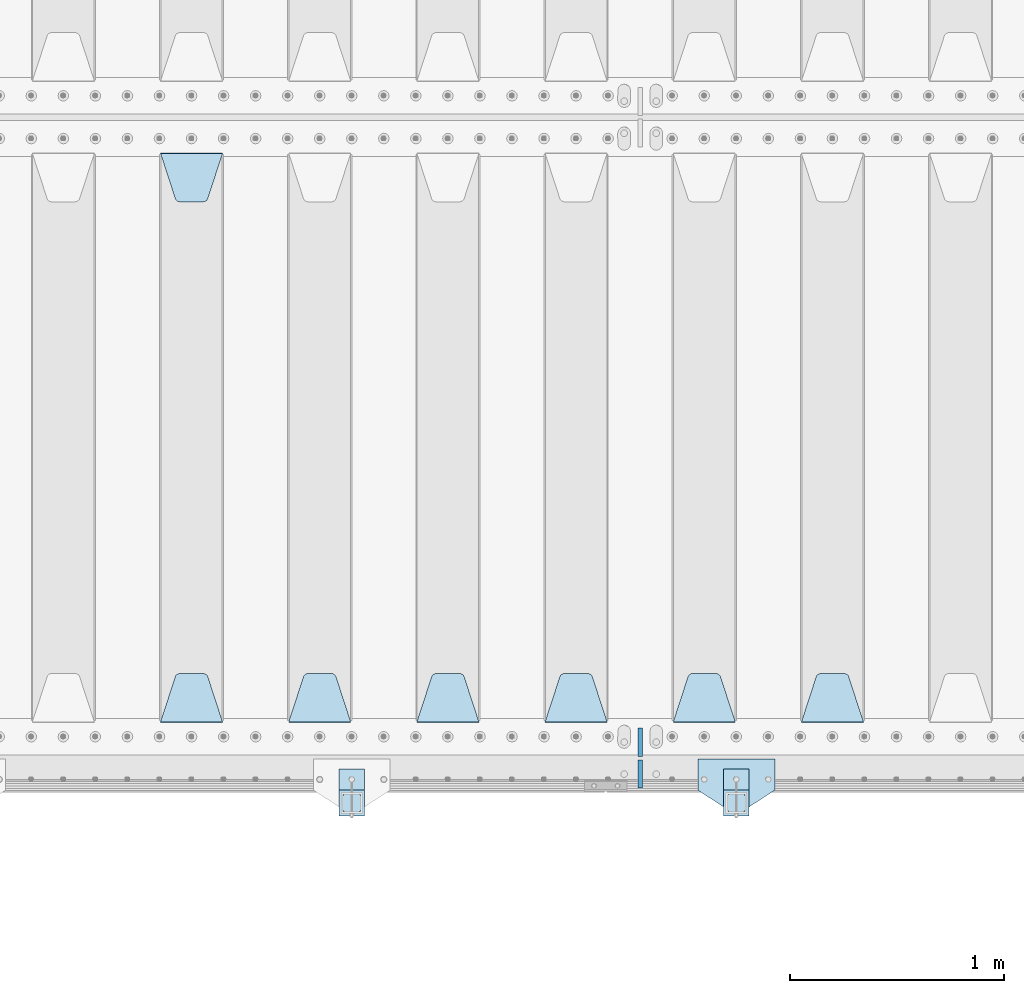
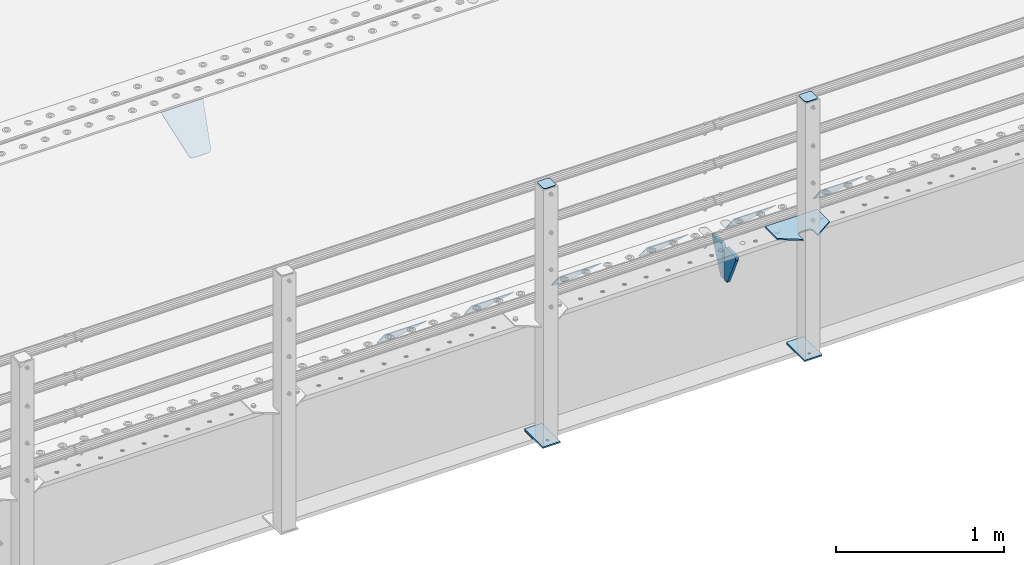
# One storey, part 168 of 208: 16 plates.
"""IFC2X3 building model written with IfcOpenShell, lengths in millimetres."""

from ifc_helpers import new_model, si_unit, frame, origin_with_axes, place, context, subcontext, project, spatial, faceted_brep, material, type_object, element, save


model = new_model("IFC2X3")

# Units and contexts
model_context = context("Model", 3, precision=1e-05, world=origin_with_axes())
body_context = subcontext(model_context, "Body", "Model", "MODEL_VIEW")
ifc_project = project(units=[si_unit("LENGTHUNIT", "METRE", prefix="MILLI"), si_unit("AREAUNIT", "SQUARE_METRE"), si_unit("VOLUMEUNIT", "CUBIC_METRE"), si_unit("MASSUNIT", "GRAM", prefix="KILO"), si_unit("TIMEUNIT", "SECOND"), si_unit("PLANEANGLEUNIT", "RADIAN"), si_unit("SOLIDANGLEUNIT", "STERADIAN"), si_unit("THERMODYNAMICTEMPERATUREUNIT", "DEGREE_CELSIUS"), si_unit("LUMINOUSINTENSITYUNIT", "LUMEN")], contexts=[model_context])

# Site, building, storey
site_placement = place(None, origin_with_axes())
site = spatial("IfcSite", under=ifc_project, at=site_placement, CompositionType="ELEMENT")
building_placement = place(site_placement, origin_with_axes())
building = spatial("IfcBuilding", under=site, at=building_placement, Name="Standard", CompositionType="ELEMENT")
storey_placement = place(building_placement, origin_with_axes())
storey = spatial("IfcBuildingStorey", under=building, at=storey_placement, Name="Undefined", CompositionType="ELEMENT", Elevation=0.0)

# Plates
ifc_material_1 = material(Name="STEEL/S355N")
plate_type_1 = type_object("IfcPlateType", PredefinedType="NOTDEFINED")
plate_1_placement = place(storey_placement, frame((-35905.0, 168.232233047023, -1.76776695296758), z_axis=(0.0, 0.707106781186547, -0.707106781186548), x_axis=(-1.0, 0.0, 0.0)))
element("IfcPlate", 1, at=plate_1_placement, inside=storey, type_object=plate_type_1, material=ifc_material_1, context=body_context, shape_type="Brep", body=[
    faceted_brep([(0.0, -2.5, 0.0), (69.345504679477, -2.5, 300.17173142483), (69.345504679477, 2.5, 300.17173142483), (0.0, 2.5, 0.0), (70.9274061199576, -2.5, 304.897442415399), (70.9274061199576, 2.5, 304.8974424154), (73.3818627772307, -2.5, 309.234538108527), (73.3818627772307, 2.5, 309.234538108527), (76.6187032999551, -2.5, 313.023683126103), (76.6187032999551, 2.5, 313.023683126103), (80.5190132704993, -2.5, 316.125672595371), (80.5190132704993, 2.5, 316.125672595371), (84.9395038596849, -2.5, 318.426546230476), (84.9395038596849, 2.50000000000091, 318.426546230476), (89.7177759439219, -2.5, 319.841774983275), (89.7177759439219, 2.50000000000091, 319.841774983275), (94.678286292652, -2.49999999999909, 320.319366455078), (94.678286292652, 2.5, 320.319366455078), (195.321713707348, -2.49999999999909, 320.319366455078), (195.321713707348, 2.5, 320.319366455078), (200.282224056078, -2.5, 319.841774983275), (200.282224056078, 2.5, 319.841774983274), (205.060496140315, -2.5, 318.426546230475), (205.060496140315, 2.5, 318.426546230475), (209.480986729501, -2.5, 316.125672595371), (209.480986729501, 2.50000000000091, 316.125672595371), (213.381296700045, -2.5, 313.023683126102), (213.381296700045, 2.5, 313.023683126102), (216.618137222769, -2.5, 309.234538108526), (216.618137222769, 2.5, 309.234538108527), (219.072593880042, -2.5, 304.897442415399), (219.072593880042, 2.5, 304.897442415399), (220.654495320523, -2.5, 300.17173142483), (220.654495320523, 2.5, 300.17173142483), (290.0, -2.5, 0.0), (290.0, 2.5, 0.0)], [[[0, 1, 2, 3]], [[1, 4, 5, 2]], [[4, 6, 7, 5]], [[6, 8, 9, 7]], [[8, 10, 11, 9]], [[10, 12, 13, 11]], [[12, 14, 15, 13]], [[14, 16, 17, 15]], [[16, 18, 19, 17]], [[18, 20, 21, 19]], [[20, 22, 23, 21]], [[22, 24, 25, 23]], [[24, 26, 27, 25]], [[26, 28, 29, 27]], [[28, 30, 31, 29]], [[30, 32, 33, 31]], [[32, 34, 35, 33]], [[34, 0, 3, 35]], [[5, 7, 9, 11, 13, 15, 17, 19, 21, 23, 25, 27, 29, 31, 33, 35, 3, 2]], [[34, 32, 30, 28, 26, 24, 22, 20, 18, 16, 14, 12, 10, 8, 6, 4, 1, 0]]]),
])
plate_2_placement = place(storey_placement, frame((-36505.0, 168.232233047023, -1.76776695296758), z_axis=(0.0, 0.707106781186547, -0.707106781186548), x_axis=(-1.0, 0.0, 0.0)))
element("IfcPlate", 2, at=plate_2_placement, inside=storey, type_object=plate_type_1, material=ifc_material_1, context=body_context, shape_type="Brep", body=[
    faceted_brep([(0.0, -2.5, 0.0), (69.345504679477, -2.5, 300.17173142483), (69.345504679477, 2.5, 300.17173142483), (0.0, 2.5, 0.0), (70.9274061199576, -2.5, 304.897442415399), (70.9274061199576, 2.5, 304.8974424154), (73.3818627772307, -2.5, 309.234538108527), (73.3818627772307, 2.5, 309.234538108527), (76.6187032999551, -2.5, 313.023683126103), (76.6187032999551, 2.5, 313.023683126103), (80.5190132704993, -2.5, 316.125672595371), (80.5190132704993, 2.5, 316.125672595371), (84.9395038596849, -2.5, 318.426546230476), (84.9395038596849, 2.50000000000091, 318.426546230476), (89.7177759439219, -2.5, 319.841774983275), (89.7177759439219, 2.50000000000091, 319.841774983275), (94.678286292652, -2.49999999999909, 320.319366455078), (94.678286292652, 2.5, 320.319366455078), (195.321713707348, -2.49999999999909, 320.319366455078), (195.321713707348, 2.5, 320.319366455078), (200.282224056078, -2.5, 319.841774983275), (200.282224056078, 2.5, 319.841774983274), (205.060496140315, -2.5, 318.426546230475), (205.060496140315, 2.5, 318.426546230475), (209.480986729501, -2.5, 316.125672595371), (209.480986729501, 2.50000000000091, 316.125672595371), (213.381296700045, -2.5, 313.023683126102), (213.381296700045, 2.5, 313.023683126102), (216.618137222769, -2.5, 309.234538108526), (216.618137222769, 2.5, 309.234538108527), (219.072593880042, -2.5, 304.897442415399), (219.072593880042, 2.5, 304.897442415399), (220.654495320523, -2.5, 300.17173142483), (220.654495320523, 2.5, 300.17173142483), (290.0, -2.5, 0.0), (290.0, 2.5, 0.0)], [[[0, 1, 2, 3]], [[1, 4, 5, 2]], [[4, 6, 7, 5]], [[6, 8, 9, 7]], [[8, 10, 11, 9]], [[10, 12, 13, 11]], [[12, 14, 15, 13]], [[14, 16, 17, 15]], [[16, 18, 19, 17]], [[18, 20, 21, 19]], [[20, 22, 23, 21]], [[22, 24, 25, 23]], [[24, 26, 27, 25]], [[26, 28, 29, 27]], [[28, 30, 31, 29]], [[30, 32, 33, 31]], [[32, 34, 35, 33]], [[34, 0, 3, 35]], [[5, 7, 9, 11, 13, 15, 17, 19, 21, 23, 25, 27, 29, 31, 33, 35, 3, 2]], [[34, 32, 30, 28, 26, 24, 22, 20, 18, 16, 14, 12, 10, 8, 6, 4, 1, 0]]]),
])
plate_3_placement = place(storey_placement, frame((-37105.0, 168.232233047023, -1.76776695296758), z_axis=(0.0, 0.707106781186547, -0.707106781186548), x_axis=(-1.0, 0.0, 0.0)))
element("IfcPlate", 3, at=plate_3_placement, inside=storey, type_object=plate_type_1, material=ifc_material_1, context=body_context, shape_type="Brep", body=[
    faceted_brep([(0.0, -2.5, 0.0), (69.345504679477, -2.5, 300.17173142483), (69.345504679477, 2.5, 300.17173142483), (0.0, 2.5, 0.0), (70.9274061199576, -2.5, 304.897442415399), (70.9274061199576, 2.5, 304.8974424154), (73.3818627772307, -2.5, 309.234538108527), (73.3818627772307, 2.5, 309.234538108527), (76.6187032999551, -2.5, 313.023683126103), (76.6187032999551, 2.5, 313.023683126103), (80.5190132704993, -2.5, 316.125672595371), (80.5190132704993, 2.5, 316.125672595371), (84.9395038596849, -2.5, 318.426546230476), (84.9395038596849, 2.50000000000091, 318.426546230476), (89.7177759439219, -2.5, 319.841774983275), (89.7177759439219, 2.50000000000091, 319.841774983275), (94.678286292652, -2.49999999999909, 320.319366455078), (94.678286292652, 2.5, 320.319366455078), (195.321713707348, -2.49999999999909, 320.319366455078), (195.321713707348, 2.5, 320.319366455078), (200.282224056078, -2.5, 319.841774983275), (200.282224056078, 2.5, 319.841774983274), (205.060496140315, -2.5, 318.426546230475), (205.060496140315, 2.5, 318.426546230475), (209.480986729501, -2.5, 316.125672595371), (209.480986729501, 2.50000000000091, 316.125672595371), (213.381296700045, -2.5, 313.023683126102), (213.381296700045, 2.5, 313.023683126102), (216.618137222769, -2.5, 309.234538108526), (216.618137222769, 2.5, 309.234538108527), (219.072593880042, -2.5, 304.897442415399), (219.072593880042, 2.5, 304.897442415399), (220.654495320523, -2.5, 300.17173142483), (220.654495320523, 2.5, 300.17173142483), (290.0, -2.5, 0.0), (290.0, 2.5, 0.0)], [[[0, 1, 2, 3]], [[1, 4, 5, 2]], [[4, 6, 7, 5]], [[6, 8, 9, 7]], [[8, 10, 11, 9]], [[10, 12, 13, 11]], [[12, 14, 15, 13]], [[14, 16, 17, 15]], [[16, 18, 19, 17]], [[18, 20, 21, 19]], [[20, 22, 23, 21]], [[22, 24, 25, 23]], [[24, 26, 27, 25]], [[26, 28, 29, 27]], [[28, 30, 31, 29]], [[30, 32, 33, 31]], [[32, 34, 35, 33]], [[34, 0, 3, 35]], [[5, 7, 9, 11, 13, 15, 17, 19, 21, 23, 25, 27, 29, 31, 33, 35, 3, 2]], [[34, 32, 30, 28, 26, 24, 22, 20, 18, 16, 14, 12, 10, 8, 6, 4, 1, 0]]]),
])
plate_4_placement = place(storey_placement, frame((-37705.0, 168.232233047023, -1.76776695296758), z_axis=(0.0, 0.707106781186547, -0.707106781186548), x_axis=(-1.0, 0.0, 0.0)))
element("IfcPlate", 4, at=plate_4_placement, inside=storey, type_object=plate_type_1, material=ifc_material_1, context=body_context, shape_type="Brep", body=[
    faceted_brep([(0.0, -2.5, 0.0), (69.345504679477, -2.5, 300.17173142483), (69.345504679477, 2.5, 300.17173142483), (0.0, 2.5, 0.0), (70.9274061199576, -2.5, 304.897442415399), (70.9274061199576, 2.5, 304.8974424154), (73.3818627772307, -2.5, 309.234538108527), (73.3818627772307, 2.5, 309.234538108527), (76.6187032999551, -2.5, 313.023683126103), (76.6187032999551, 2.5, 313.023683126103), (80.5190132704993, -2.5, 316.125672595371), (80.5190132704993, 2.5, 316.125672595371), (84.9395038596849, -2.5, 318.426546230476), (84.9395038596849, 2.50000000000091, 318.426546230476), (89.7177759439219, -2.5, 319.841774983275), (89.7177759439219, 2.50000000000091, 319.841774983275), (94.678286292652, -2.49999999999909, 320.319366455078), (94.678286292652, 2.5, 320.319366455078), (195.321713707348, -2.49999999999909, 320.319366455078), (195.321713707348, 2.5, 320.319366455078), (200.282224056078, -2.5, 319.841774983275), (200.282224056078, 2.5, 319.841774983274), (205.060496140315, -2.5, 318.426546230475), (205.060496140315, 2.5, 318.426546230475), (209.480986729501, -2.5, 316.125672595371), (209.480986729501, 2.50000000000091, 316.125672595371), (213.381296700045, -2.5, 313.023683126102), (213.381296700045, 2.5, 313.023683126102), (216.618137222769, -2.5, 309.234538108526), (216.618137222769, 2.5, 309.234538108527), (219.072593880042, -2.5, 304.897442415399), (219.072593880042, 2.5, 304.897442415399), (220.654495320523, -2.5, 300.17173142483), (220.654495320523, 2.5, 300.17173142483), (290.0, -2.5, 0.0), (290.0, 2.5, 0.0)], [[[0, 1, 2, 3]], [[1, 4, 5, 2]], [[4, 6, 7, 5]], [[6, 8, 9, 7]], [[8, 10, 11, 9]], [[10, 12, 13, 11]], [[12, 14, 15, 13]], [[14, 16, 17, 15]], [[16, 18, 19, 17]], [[18, 20, 21, 19]], [[20, 22, 23, 21]], [[22, 24, 25, 23]], [[24, 26, 27, 25]], [[26, 28, 29, 27]], [[28, 30, 31, 29]], [[30, 32, 33, 31]], [[32, 34, 35, 33]], [[34, 0, 3, 35]], [[5, 7, 9, 11, 13, 15, 17, 19, 21, 23, 25, 27, 29, 31, 33, 35, 3, 2]], [[34, 32, 30, 28, 26, 24, 22, 20, 18, 16, 14, 12, 10, 8, 6, 4, 1, 0]]]),
])
plate_5_placement = place(storey_placement, frame((-38305.0, 168.232233047023, -1.76776695296758), z_axis=(0.0, 0.707106781186547, -0.707106781186548), x_axis=(-1.0, 0.0, 0.0)))
element("IfcPlate", 5, at=plate_5_placement, inside=storey, type_object=plate_type_1, material=ifc_material_1, context=body_context, shape_type="Brep", body=[
    faceted_brep([(0.0, -2.5, 0.0), (69.345504679477, -2.5, 300.17173142483), (69.345504679477, 2.5, 300.17173142483), (0.0, 2.5, 0.0), (70.9274061199576, -2.5, 304.897442415399), (70.9274061199576, 2.5, 304.8974424154), (73.3818627772307, -2.5, 309.234538108527), (73.3818627772307, 2.5, 309.234538108527), (76.6187032999551, -2.5, 313.023683126103), (76.6187032999551, 2.5, 313.023683126103), (80.5190132704993, -2.5, 316.125672595371), (80.5190132704993, 2.5, 316.125672595371), (84.9395038596849, -2.5, 318.426546230476), (84.9395038596849, 2.50000000000091, 318.426546230476), (89.7177759439219, -2.5, 319.841774983275), (89.7177759439219, 2.50000000000091, 319.841774983275), (94.678286292652, -2.49999999999909, 320.319366455078), (94.678286292652, 2.5, 320.319366455078), (195.321713707348, -2.49999999999909, 320.319366455078), (195.321713707348, 2.5, 320.319366455078), (200.282224056078, -2.5, 319.841774983275), (200.282224056078, 2.5, 319.841774983274), (205.060496140315, -2.5, 318.426546230475), (205.060496140315, 2.5, 318.426546230475), (209.480986729501, -2.5, 316.125672595371), (209.480986729501, 2.50000000000091, 316.125672595371), (213.381296700045, -2.5, 313.023683126102), (213.381296700045, 2.5, 313.023683126102), (216.618137222769, -2.5, 309.234538108526), (216.618137222769, 2.5, 309.234538108527), (219.072593880042, -2.5, 304.897442415399), (219.072593880042, 2.5, 304.897442415399), (220.654495320523, -2.5, 300.17173142483), (220.654495320523, 2.5, 300.17173142483), (290.0, -2.5, 0.0), (290.0, 2.5, 0.0)], [[[0, 1, 2, 3]], [[1, 4, 5, 2]], [[4, 6, 7, 5]], [[6, 8, 9, 7]], [[8, 10, 11, 9]], [[10, 12, 13, 11]], [[12, 14, 15, 13]], [[14, 16, 17, 15]], [[16, 18, 19, 17]], [[18, 20, 21, 19]], [[20, 22, 23, 21]], [[22, 24, 25, 23]], [[24, 26, 27, 25]], [[26, 28, 29, 27]], [[28, 30, 31, 29]], [[30, 32, 33, 31]], [[32, 34, 35, 33]], [[34, 0, 3, 35]], [[5, 7, 9, 11, 13, 15, 17, 19, 21, 23, 25, 27, 29, 31, 33, 35, 3, 2]], [[34, 32, 30, 28, 26, 24, 22, 20, 18, 16, 14, 12, 10, 8, 6, 4, 1, 0]]]),
])
plate_6_placement = place(storey_placement, frame((-39195.0, 2831.76776695596, -1.76776695296758), z_axis=(0.0, -0.707106781186548, -0.707106781186547), x_axis=(1.0, 0.0, 0.0)))
element("IfcPlate", 6, at=plate_6_placement, inside=storey, type_object=plate_type_1, material=ifc_material_1, context=body_context, shape_type="Brep", body=[
    faceted_brep([(0.0, -2.5, 0.0), (69.345504679477, -2.5, 300.17173142483), (69.345504679477, 2.5, 300.17173142483), (0.0, 2.5, 0.0), (70.9274061199576, -2.5, 304.897442415399), (70.9274061199576, 2.5, 304.8974424154), (73.3818627772307, -2.5, 309.234538108527), (73.3818627772307, 2.5, 309.234538108527), (76.6187032999551, -2.5, 313.023683126103), (76.6187032999551, 2.5, 313.023683126103), (80.5190132704993, -2.5, 316.125672595371), (80.5190132704993, 2.5, 316.125672595371), (84.9395038596849, -2.5, 318.426546230476), (84.9395038596849, 2.50000000000091, 318.426546230476), (89.7177759439219, -2.5, 319.841774983275), (89.7177759439219, 2.50000000000091, 319.841774983275), (94.678286292652, -2.49999999999909, 320.319366455078), (94.678286292652, 2.5, 320.319366455078), (195.321713707348, -2.49999999999909, 320.319366455078), (195.321713707348, 2.5, 320.319366455078), (200.282224056078, -2.5, 319.841774983275), (200.282224056078, 2.5, 319.841774983274), (205.060496140315, -2.5, 318.426546230475), (205.060496140315, 2.5, 318.426546230475), (209.480986729501, -2.5, 316.125672595371), (209.480986729501, 2.50000000000091, 316.125672595371), (213.381296700045, -2.5, 313.023683126102), (213.381296700045, 2.5, 313.023683126102), (216.618137222769, -2.5, 309.234538108526), (216.618137222769, 2.5, 309.234538108527), (219.072593880042, -2.5, 304.897442415399), (219.072593880042, 2.5, 304.897442415399), (220.654495320523, -2.5, 300.17173142483), (220.654495320523, 2.5, 300.17173142483), (290.0, -2.5, 0.0), (290.0, 2.5, 0.0)], [[[0, 1, 2, 3]], [[1, 4, 5, 2]], [[4, 6, 7, 5]], [[6, 8, 9, 7]], [[8, 10, 11, 9]], [[10, 12, 13, 11]], [[12, 14, 15, 13]], [[14, 16, 17, 15]], [[16, 18, 19, 17]], [[18, 20, 21, 19]], [[20, 22, 23, 21]], [[22, 24, 25, 23]], [[24, 26, 27, 25]], [[26, 28, 29, 27]], [[28, 30, 31, 29]], [[30, 32, 33, 31]], [[32, 34, 35, 33]], [[34, 0, 3, 35]], [[5, 7, 9, 11, 13, 15, 17, 19, 21, 23, 25, 27, 29, 31, 33, 35, 3, 2]], [[34, 32, 30, 28, 26, 24, 22, 20, 18, 16, 14, 12, 10, 8, 6, 4, 1, 0]]]),
])
plate_7_placement = place(storey_placement, frame((-38905.0, 168.232233047023, -1.76776695296758), z_axis=(0.0, 0.707106781186547, -0.707106781186548), x_axis=(-1.0, 0.0, 0.0)))
element("IfcPlate", 7, at=plate_7_placement, inside=storey, type_object=plate_type_1, material=ifc_material_1, context=body_context, shape_type="Brep", body=[
    faceted_brep([(0.0, -2.5, 0.0), (69.345504679477, -2.5, 300.17173142483), (69.345504679477, 2.5, 300.17173142483), (0.0, 2.5, 0.0), (70.9274061199576, -2.5, 304.897442415399), (70.9274061199576, 2.5, 304.8974424154), (73.3818627772307, -2.5, 309.234538108527), (73.3818627772307, 2.5, 309.234538108527), (76.6187032999551, -2.5, 313.023683126103), (76.6187032999551, 2.5, 313.023683126103), (80.5190132704993, -2.5, 316.125672595371), (80.5190132704993, 2.5, 316.125672595371), (84.9395038596849, -2.5, 318.426546230476), (84.9395038596849, 2.50000000000091, 318.426546230476), (89.7177759439219, -2.5, 319.841774983275), (89.7177759439219, 2.50000000000091, 319.841774983275), (94.678286292652, -2.49999999999909, 320.319366455078), (94.678286292652, 2.5, 320.319366455078), (195.321713707348, -2.49999999999909, 320.319366455078), (195.321713707348, 2.5, 320.319366455078), (200.282224056078, -2.5, 319.841774983275), (200.282224056078, 2.5, 319.841774983274), (205.060496140315, -2.5, 318.426546230475), (205.060496140315, 2.5, 318.426546230475), (209.480986729501, -2.5, 316.125672595371), (209.480986729501, 2.50000000000091, 316.125672595371), (213.381296700045, -2.5, 313.023683126102), (213.381296700045, 2.5, 313.023683126102), (216.618137222769, -2.5, 309.234538108526), (216.618137222769, 2.5, 309.234538108527), (219.072593880042, -2.5, 304.897442415399), (219.072593880042, 2.5, 304.897442415399), (220.654495320523, -2.5, 300.17173142483), (220.654495320523, 2.5, 300.17173142483), (290.0, -2.5, 0.0), (290.0, 2.5, 0.0)], [[[0, 1, 2, 3]], [[1, 4, 5, 2]], [[4, 6, 7, 5]], [[6, 8, 9, 7]], [[8, 10, 11, 9]], [[10, 12, 13, 11]], [[12, 14, 15, 13]], [[14, 16, 17, 15]], [[16, 18, 19, 17]], [[18, 20, 21, 19]], [[20, 22, 23, 21]], [[22, 24, 25, 23]], [[24, 26, 27, 25]], [[26, 28, 29, 27]], [[28, 30, 31, 29]], [[30, 32, 33, 31]], [[32, 34, 35, 33]], [[34, 0, 3, 35]], [[5, 7, 9, 11, 13, 15, 17, 19, 21, 23, 25, 27, 29, 31, 33, 35, 3, 2]], [[34, 32, 30, 28, 26, 24, 22, 20, 18, 16, 14, 12, 10, 8, 6, 4, 1, 0]]]),
])
plate_type_2 = type_object("IfcPlateType", PredefinedType="NOTDEFINED")
for number, where, z_axis, x_axis in (
    (8, (-36950.0, 140.0, -30.0), (0.0, 0.0, -1.0), (0.0, -1.0, 0.0)),
    (9, (-36950.0, -140.0, -30.0), (0.0, 0.0, -1.0), (0.0, 1.0, 0.0)),
):
    element("IfcPlate", number, at=place(storey_placement, frame(where, z_axis=z_axis, x_axis=x_axis)), inside=storey, type_object=plate_type_2, material=ifc_material_1, context=body_context, shape_type="Brep", body=[
        faceted_brep([(0.0, -10.0, 0.0), (0.0, -10.0, 30.0), (0.0, 10.0, 30.0), (0.0, 10.0, 0.0), (102.0, -10.0, 250.0), (102.0, 10.0, 250.0), (132.0, -10.0, 250.0), (132.0, 10.0, 250.0), (132.0, -10.0, 30.0), (132.0, 10.0, 30.0), (131.544232590366, -10.0, 24.790554669992), (131.544232590366, 10.0, 24.790554669992), (130.190778623577, -10.0, 19.7393957002299), (130.190778623577, 10.0, 19.7393957002299), (127.980762113533, -10.0, 15.0), (127.980762113533, 10.0, 15.0), (124.981333293569, -10.0, 10.7163717094038), (124.981333293569, 10.0, 10.7163717094038), (121.283628290596, -10.0, 7.01866670643062), (121.283628290596, 10.0, 7.01866670643062), (117.0, -10.0, 4.01923788646684), (117.0, 10.0, 4.01923788646684), (112.26060429977, -10.0, 1.80922137642278), (112.26060429977, 10.0, 1.80922137642278), (107.209445330008, -10.0, 0.455767409633722), (107.209445330008, 10.0, 0.455767409633722), (102.0, -10.0, 0.0), (102.0, 10.0, 0.0)], [[[0, 1, 2, 3]], [[1, 4, 5, 2]], [[4, 6, 7, 5]], [[6, 8, 9, 7]], [[8, 10, 11, 9]], [[10, 12, 13, 11]], [[12, 14, 15, 13]], [[14, 16, 17, 15]], [[16, 18, 19, 17]], [[18, 20, 21, 19]], [[20, 22, 23, 21]], [[22, 24, 25, 23]], [[24, 26, 27, 25]], [[26, 0, 3, 27]], [[5, 7, 9, 11, 13, 15, 17, 19, 21, 23, 25, 27, 3, 2]], [[26, 24, 22, 20, 18, 16, 14, 12, 10, 8, 6, 4, 1, 0]]]),
    ])
ifc_material_2 = material(Name="STEEL/S355J2")
plate_type_3 = type_object("IfcPlateType", PredefinedType="NOTDEFINED")
plate_8_placement = place(storey_placement, frame((-36320.0, -4.99999999999636, 5.00000000004911), z_axis=(0.0, -1.0, 0.0), x_axis=(-1.0, 0.0, 0.0)))
element("IfcPlate", 10, at=plate_8_placement, inside=storey, type_object=plate_type_3, material=ifc_material_2, context=body_context, shape_type="Brep", body=[
    faceted_brep([(0.0, -5.0, 0.0), (2.31396552408114e-06, -5.0, 145.0), (2.31396552408114e-06, 5.0, 145.0), (0.0, 5.0, 0.0), (130.0, -5.0, 230.0), (130.0, 5.0, 230.0), (130.0, -5.0, 180.0), (130.0, 5.0, 180.0), (130.48036798992, -5.0, 175.122741949597), (130.48036798992, 5.0, 175.122741949597), (131.903011687216, -5.0, 170.432914190873), (131.903011687216, 5.0, 170.432914190873), (134.213259692435, -5.0, 166.11074417451), (134.213259692435, 5.0, 166.11074417451), (137.322330470335, -5.0, 162.322330470336), (137.322330470335, 5.0, 162.322330470336), (141.110744174512, -5.0, 159.213259692437), (141.110744174512, 5.0, 159.213259692437), (145.432914190871, -5.0, 156.903011687218), (145.432914190871, 5.0, 156.903011687218), (150.122741949595, -5.0, 155.48036798992), (150.122741949595, 5.0, 155.48036798992), (155.0, -5.0, 155.0), (155.0, 5.0, 155.0), (205.0, -5.0, 155.0), (205.0, 5.0, 155.0), (209.877258050405, -5.0, 155.48036798992), (209.877258050405, 5.0, 155.48036798992), (214.567085809129, -5.0, 156.903011687218), (214.567085809129, 5.0, 156.903011687218), (218.889255825488, -5.0, 159.213259692437), (218.889255825488, 5.0, 159.213259692437), (222.677669529665, -5.0, 162.322330470336), (222.677669529665, 5.0, 162.322330470336), (225.786740307565, -5.0, 166.11074417451), (225.786740307565, 5.0, 166.11074417451), (228.096988312784, -5.0, 170.432914190873), (228.096988312784, 5.0, 170.432914190873), (229.51963201008, -5.0, 175.122741949597), (229.51963201008, 5.0, 175.122741949597), (230.0, -5.0, 180.0), (230.0, 5.0, 180.0), (230.0, -5.0, 230.0), (230.0, 5.0, 230.0), (360.0, -5.0, 145.0), (360.0, 5.0, 145.0), (360.0, -5.0, -7.27595761418343e-12), (360.0, 5.0, -7.27595761418343e-12)], [[[0, 1, 2, 3]], [[1, 4, 5, 2]], [[4, 6, 7, 5]], [[6, 8, 9, 7]], [[8, 10, 11, 9]], [[10, 12, 13, 11]], [[12, 14, 15, 13]], [[14, 16, 17, 15]], [[16, 18, 19, 17]], [[18, 20, 21, 19]], [[20, 22, 23, 21]], [[22, 24, 25, 23]], [[24, 26, 27, 25]], [[26, 28, 29, 27]], [[28, 30, 31, 29]], [[30, 32, 33, 31]], [[32, 34, 35, 33]], [[34, 36, 37, 35]], [[36, 38, 39, 37]], [[38, 40, 41, 39]], [[40, 42, 43, 41]], [[42, 44, 45, 43]], [[44, 46, 47, 45]], [[46, 0, 3, 47]], [[5, 7, 9, 11, 13, 15, 17, 19, 21, 23, 25, 27, 29, 31, 33, 35, 37, 39, 41, 43, 45, 47, 3, 2]], [[46, 44, 42, 40, 38, 36, 34, 32, 30, 28, 26, 24, 22, 20, 18, 16, 14, 12, 10, 8, 6, 4, 1, 0]]]),
])
plate_type_4 = type_object("IfcPlateType", PredefinedType="NOTDEFINED")
for number, where, z_axis, x_axis in (
    (11, (-36440.0000000001, -50.0000000002074, -850.000000000002), (0.0, -1.0, 0.0), (-1.0, 0.0, 0.0)),
    (12, (-38240.0000000001, -50.0000000002074, -850.000000000002), (0.0, -1.0, 0.0), (-1.0, 0.0, 0.0)),
):
    element("IfcPlate", number, at=place(storey_placement, frame(where, z_axis=z_axis, x_axis=x_axis)), inside=storey, type_object=plate_type_4, material=ifc_material_2, context=body_context, shape_type="Brep", body=[
        faceted_brep([(53.6360389691836, -5.0, 176.36396103047), (53.6360389691836, 5.0, 176.36396103047), (59.9999999998618, 5.0, 178.999999999791), (59.9999999998618, -5.0, 178.999999999791), (66.3639610305399, 5.0, 176.36396103047), (66.3639610305399, -5.0, 176.36396103047), (68.9999999998618, 5.0, 169.999999999791), (68.9999999998618, -5.0, 169.999999999791), (66.3639610305399, 5.0, 163.636038969112), (66.3639610305399, -5.0, 163.636038969112), (59.9999999998618, 5.0, 160.999999999791), (59.9999999998618, -5.0, 160.999999999791), (53.6360389691836, 5.0, 163.636038969112), (53.6360389691836, -5.0, 163.636038969112), (50.9999999998618, 5.0, 169.999999999791), (50.9999999998618, -5.0, 169.999999999791), (120.0, -5.0, 0.0), (120.0, -5.0, 220.0), (0.0, -5.0, 220.0), (0.0, -5.0, 0.0), (0.0, 5.0, 0.0), (120.0, 5.0, 0.0), (120.0, 5.0, 220.0), (0.0, 5.0, 220.0)], [[[0, 1, 2, 3]], [[3, 2, 4, 5]], [[5, 4, 6, 7]], [[7, 6, 8, 9]], [[9, 8, 10, 11]], [[11, 10, 12, 13]], [[13, 12, 14, 15]], [[15, 14, 1, 0]], [[16, 17, 18, 19], [11, 13, 15, 0, 3, 5, 7, 9]], [[16, 19, 20, 21]], [[17, 16, 21, 22]], [[18, 17, 22, 23]], [[19, 18, 23, 20]], [[22, 21, 20, 23], [2, 1, 14, 12, 10, 8, 6, 4]]]),
    ])
plate_type_5 = type_object("IfcPlateType", PredefinedType="NOTDEFINED")
plate_9_placement = place(storey_placement, frame((-36544.0000000001, -166.000000000207, 1012.50000000001), z_axis=(0.0, -1.0, 0.0), x_axis=(1.0, 0.0, 0.0)))
element("IfcPlate", 13, at=plate_9_placement, inside=storey, type_object=plate_type_5, material=ifc_material_2, context=body_context, shape_type="Brep", body=[
    faceted_brep([(0.0, -2.5, 19.0), (0.0, -2.5, 69.0), (0.0, 2.5, 69.0), (0.0, 2.5, 19.0), (0.476369668544066, -2.5, 73.2278977451697), (0.476369668544066, 2.5, 73.2278977451697), (1.88159150985302, -2.5, 77.2437910432336), (1.88159150985302, 2.5, 77.2437910432336), (4.14520183310742, -2.5, 80.8463062353158), (4.14520183310742, 2.5, 80.8463062353158), (7.15369376468516, -2.5, 83.8547981668926), (7.15369376468516, 2.5, 83.8547981668926), (10.7562089567655, -2.5, 86.1184084901461), (10.7562089567655, 2.5, 86.1184084901461), (14.7721022548285, -2.5, 87.523630331455), (14.7721022548285, 2.5, 87.523630331455), (19.0, -2.5, 88.0), (19.0, 2.5, 88.0), (69.0, -2.5, 88.0), (69.0, 2.5, 88.0), (73.2278977451715, -2.5, 87.523630331455), (73.2278977451715, 2.5, 87.523630331455), (77.2437910432345, -2.5, 86.1184084901461), (77.2437910432345, 2.5, 86.1184084901461), (80.8463062353148, -2.5, 83.8547981668926), (80.8463062353148, 2.5, 83.8547981668926), (83.8547981668926, -2.5, 80.8463062353158), (83.8547981668926, 2.5, 80.8463062353158), (86.118408490147, -2.5, 77.2437910432336), (86.118408490147, 2.5, 77.2437910432336), (87.5236303314559, -2.5, 73.2278977451697), (87.5236303314559, 2.5, 73.2278977451697), (88.0, -2.5, 69.0), (88.0, 2.5, 69.0), (88.0, -2.5, 19.0), (88.0, 2.5, 19.0), (87.5236303314559, -2.5, 14.7721022548303), (87.5236303314559, 2.5, 14.7721022548303), (86.118408490147, -2.5, 10.7562089567664), (86.118408490147, 2.5, 10.7562089567664), (83.8547981668926, -2.5, 7.15369376468425), (83.8547981668926, 2.5, 7.15369376468425), (80.8463062353148, -2.5, 4.14520183310742), (80.8463062353148, 2.5, 4.14520183310742), (77.2437910432345, -2.5, 1.88159150985393), (77.2437910432345, 2.5, 1.88159150985393), (73.2278977451715, -2.5, 0.476369668544976), (73.2278977451715, 2.5, 0.476369668544976), (69.0, -2.5, 0.0), (69.0, 2.5, 0.0), (19.0, -2.5, 0.0), (19.0, 2.5, 0.0), (14.7721022548285, -2.5, 0.476369668544976), (14.7721022548285, 2.5, 0.476369668544976), (10.7562089567655, -2.5, 1.88159150985393), (10.7562089567655, 2.5, 1.88159150985393), (7.15369376468516, -2.5, 4.14520183310742), (7.15369376468516, 2.5, 4.14520183310742), (4.14520183310742, -2.5, 7.15369376468425), (4.14520183310742, 2.5, 7.15369376468425), (1.88159150985302, -2.5, 10.7562089567664), (1.88159150985302, 2.5, 10.7562089567664), (0.476369668544066, -2.5, 14.7721022548303), (0.476369668544066, 2.5, 14.7721022548303)], [[[0, 1, 2, 3]], [[1, 4, 5, 2]], [[4, 6, 7, 5]], [[6, 8, 9, 7]], [[8, 10, 11, 9]], [[10, 12, 13, 11]], [[12, 14, 15, 13]], [[14, 16, 17, 15]], [[16, 18, 19, 17]], [[18, 20, 21, 19]], [[20, 22, 23, 21]], [[22, 24, 25, 23]], [[24, 26, 27, 25]], [[26, 28, 29, 27]], [[28, 30, 31, 29]], [[30, 32, 33, 31]], [[32, 34, 35, 33]], [[34, 36, 37, 35]], [[36, 38, 39, 37]], [[38, 40, 41, 39]], [[40, 42, 43, 41]], [[42, 44, 45, 43]], [[44, 46, 47, 45]], [[46, 48, 49, 47]], [[48, 50, 51, 49]], [[50, 52, 53, 51]], [[52, 54, 55, 53]], [[54, 56, 57, 55]], [[56, 58, 59, 57]], [[58, 60, 61, 59]], [[60, 62, 63, 61]], [[62, 0, 3, 63]], [[5, 7, 9, 11, 13, 15, 17, 19, 21, 23, 25, 27, 29, 31, 33, 35, 37, 39, 41, 43, 45, 47, 49, 51, 53, 55, 57, 59, 61, 63, 3, 2]], [[62, 60, 58, 56, 54, 52, 50, 48, 46, 44, 42, 40, 38, 36, 34, 32, 30, 28, 26, 24, 22, 20, 18, 16, 14, 12, 10, 8, 6, 4, 1, 0]]]),
])
plate_10_placement = place(storey_placement, frame((-38344.0000000001, -166.000000000207, 1012.50000000001), z_axis=(0.0, -1.0, 0.0), x_axis=(1.0, 0.0, 0.0)))
element("IfcPlate", 14, at=plate_10_placement, inside=storey, type_object=plate_type_5, material=ifc_material_2, context=body_context, shape_type="Brep", body=[
    faceted_brep([(0.0, -2.5, 19.0), (0.0, -2.5, 69.0), (0.0, 2.5, 69.0), (0.0, 2.5, 19.0), (0.476369668544066, -2.5, 73.2278977451697), (0.476369668544066, 2.5, 73.2278977451697), (1.88159150985302, -2.5, 77.2437910432336), (1.88159150985302, 2.5, 77.2437910432336), (4.14520183310742, -2.5, 80.8463062353158), (4.14520183310742, 2.5, 80.8463062353158), (7.15369376468516, -2.5, 83.8547981668926), (7.15369376468516, 2.5, 83.8547981668926), (10.7562089567655, -2.5, 86.1184084901461), (10.7562089567655, 2.5, 86.1184084901461), (14.7721022548285, -2.5, 87.523630331455), (14.7721022548285, 2.5, 87.523630331455), (19.0, -2.5, 88.0), (19.0, 2.5, 88.0), (69.0, -2.5, 88.0), (69.0, 2.5, 88.0), (73.2278977451715, -2.5, 87.523630331455), (73.2278977451715, 2.5, 87.523630331455), (77.2437910432345, -2.5, 86.1184084901461), (77.2437910432345, 2.5, 86.1184084901461), (80.8463062353148, -2.5, 83.8547981668926), (80.8463062353148, 2.5, 83.8547981668926), (83.8547981668926, -2.5, 80.8463062353158), (83.8547981668926, 2.5, 80.8463062353158), (86.118408490147, -2.5, 77.2437910432336), (86.118408490147, 2.5, 77.2437910432336), (87.5236303314559, -2.5, 73.2278977451697), (87.5236303314559, 2.5, 73.2278977451697), (88.0, -2.5, 69.0), (88.0, 2.5, 69.0), (88.0, -2.5, 19.0), (88.0, 2.5, 19.0), (87.5236303314559, -2.5, 14.7721022548303), (87.5236303314559, 2.5, 14.7721022548303), (86.118408490147, -2.5, 10.7562089567664), (86.118408490147, 2.5, 10.7562089567664), (83.8547981668926, -2.5, 7.15369376468425), (83.8547981668926, 2.5, 7.15369376468425), (80.8463062353148, -2.5, 4.14520183310742), (80.8463062353148, 2.5, 4.14520183310742), (77.2437910432345, -2.5, 1.88159150985393), (77.2437910432345, 2.5, 1.88159150985393), (73.2278977451715, -2.5, 0.476369668544976), (73.2278977451715, 2.5, 0.476369668544976), (69.0, -2.5, 0.0), (69.0, 2.5, 0.0), (19.0, -2.5, 0.0), (19.0, 2.5, 0.0), (14.7721022548285, -2.5, 0.476369668544976), (14.7721022548285, 2.5, 0.476369668544976), (10.7562089567655, -2.5, 1.88159150985393), (10.7562089567655, 2.5, 1.88159150985393), (7.15369376468516, -2.5, 4.14520183310742), (7.15369376468516, 2.5, 4.14520183310742), (4.14520183310742, -2.5, 7.15369376468425), (4.14520183310742, 2.5, 7.15369376468425), (1.88159150985302, -2.5, 10.7562089567664), (1.88159150985302, 2.5, 10.7562089567664), (0.476369668544066, -2.5, 14.7721022548303), (0.476369668544066, 2.5, 14.7721022548303)], [[[0, 1, 2, 3]], [[1, 4, 5, 2]], [[4, 6, 7, 5]], [[6, 8, 9, 7]], [[8, 10, 11, 9]], [[10, 12, 13, 11]], [[12, 14, 15, 13]], [[14, 16, 17, 15]], [[16, 18, 19, 17]], [[18, 20, 21, 19]], [[20, 22, 23, 21]], [[22, 24, 25, 23]], [[24, 26, 27, 25]], [[26, 28, 29, 27]], [[28, 30, 31, 29]], [[30, 32, 33, 31]], [[32, 34, 35, 33]], [[34, 36, 37, 35]], [[36, 38, 39, 37]], [[38, 40, 41, 39]], [[40, 42, 43, 41]], [[42, 44, 45, 43]], [[44, 46, 47, 45]], [[46, 48, 49, 47]], [[48, 50, 51, 49]], [[50, 52, 53, 51]], [[52, 54, 55, 53]], [[54, 56, 57, 55]], [[56, 58, 59, 57]], [[58, 60, 61, 59]], [[60, 62, 63, 61]], [[62, 0, 3, 63]], [[5, 7, 9, 11, 13, 15, 17, 19, 21, 23, 25, 27, 29, 31, 33, 35, 37, 39, 41, 43, 45, 47, 49, 51, 53, 55, 57, 59, 61, 63, 3, 2]], [[62, 60, 58, 56, 54, 52, 50, 48, 46, 44, 42, 40, 38, 36, 34, 32, 30, 28, 26, 24, 22, 20, 18, 16, 14, 12, 10, 8, 6, 4, 1, 0]]]),
])
plate_type_6 = type_object("IfcPlateType", PredefinedType="NOTDEFINED")
for number, where, z_axis, x_axis in (
    (15, (-36440.0000000001, -50.0000000002074, -857.500000000002), (0.0, -1.0, 0.0), (-1.0, 0.0, 0.0)),
    (16, (-38240.0000000001, -50.0000000002074, -857.500000000002), (0.0, -1.0, 0.0), (-1.0, 0.0, 0.0)),
):
    element("IfcPlate", number, at=place(storey_placement, frame(where, z_axis=z_axis, x_axis=x_axis)), inside=storey, type_object=plate_type_6, material=ifc_material_2, context=body_context, shape_type="Brep", body=[
        faceted_brep([(0.0, -2.5, 0.0), (0.0, -2.5, 100.0), (0.0, 2.5, 100.0), (0.0, 2.5, 0.0), (120.0, -2.5, 100.0), (120.0, 2.5, 100.0), (120.0, -2.5, 0.0), (120.0, 2.5, 0.0)], [[[0, 1, 2, 3]], [[1, 4, 5, 2]], [[4, 6, 7, 5]], [[6, 0, 3, 7]], [[5, 7, 3, 2]], [[6, 4, 1, 0]]]),
    ])

save(model, "model.ifc")
